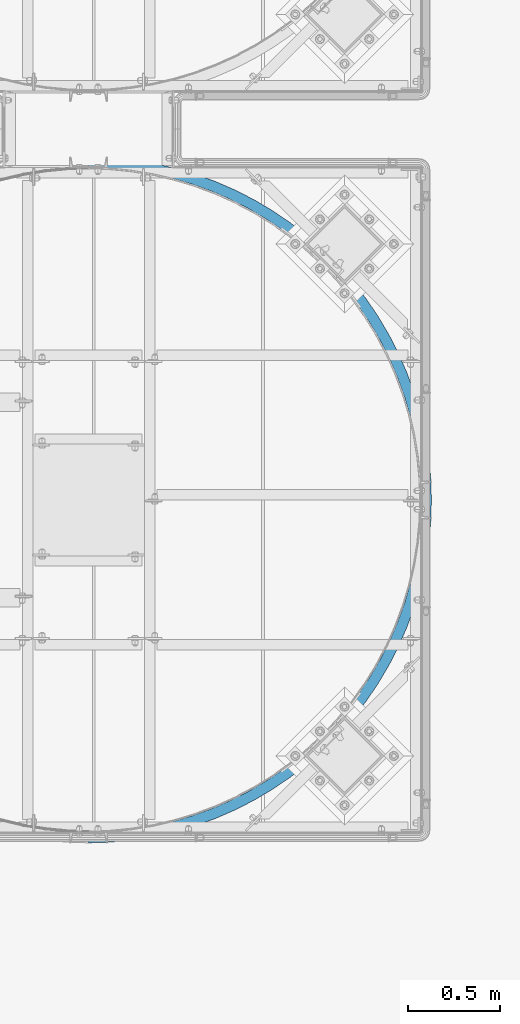
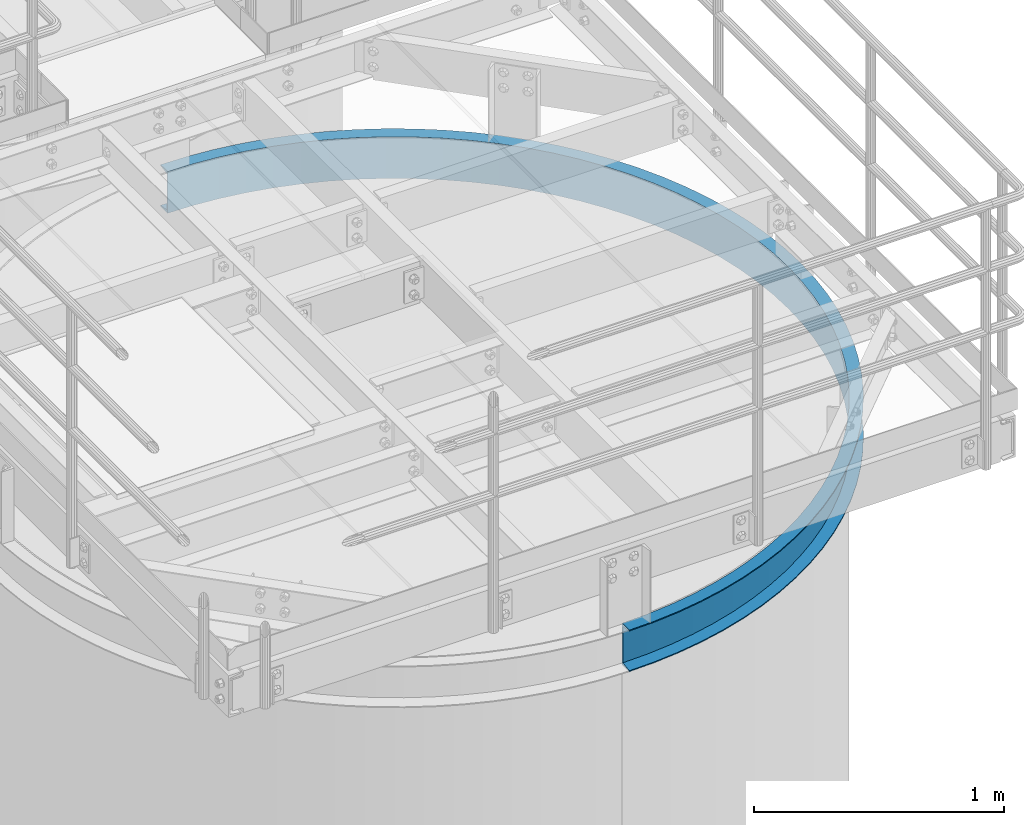
# One storey, part 923 of 1876: 1 beam, 1 element without a shape of its own.
"""IFC2X3 building model written with IfcOpenShell, lengths in millimetres."""

from ifc_helpers import new_model, si_unit, frame, origin_with_axes, place, context, subcontext, project, spatial, faceted_brep, material, type_object, element, aggregate, save


model = new_model("IFC2X3")

# Units and contexts
model_context = context("Model", 3, precision=1e-05, world=origin_with_axes())
body_context = subcontext(model_context, "Body", "Model", "MODEL_VIEW")
ifc_project = project(units=[si_unit("LENGTHUNIT", "METRE", prefix="MILLI"), si_unit("AREAUNIT", "SQUARE_METRE"), si_unit("VOLUMEUNIT", "CUBIC_METRE"), si_unit("MASSUNIT", "GRAM", prefix="KILO"), si_unit("TIMEUNIT", "SECOND"), si_unit("PLANEANGLEUNIT", "RADIAN"), si_unit("SOLIDANGLEUNIT", "STERADIAN"), si_unit("THERMODYNAMICTEMPERATUREUNIT", "DEGREE_CELSIUS"), si_unit("LUMINOUSINTENSITYUNIT", "LUMEN")], contexts=[model_context])

# Site, building, storey
site_placement = place(None, origin_with_axes())
site = spatial("IfcSite", under=ifc_project, at=site_placement, CompositionType="ELEMENT")
building_placement = place(site_placement, origin_with_axes())
building = spatial("IfcBuilding", under=site, at=building_placement, Name="Undefined", CompositionType="ELEMENT")
storey_placement = place(building_placement, origin_with_axes())
storey = spatial("IfcBuildingStorey", under=building, at=storey_placement, Name="Undefined", CompositionType="ELEMENT", Elevation=0.0)

# Assembly, beam
assembly_placement = place(storey_placement, origin_with_axes())
assembly = element("IfcElementAssembly", 1, at=assembly_placement, inside=storey, Name="CHANNEL", AssemblyPlace="NOTDEFINED", PredefinedType="RIGID_FRAME")
ifc_material = material(Name="STEEL/A36")
beam_type = type_object("IfcBeamType", Name="C8X11.5", PredefinedType="NOTDEFINED")
beam_placement = place(assembly_placement, frame((5201.80416918465, -15425.2699805693, 7518.4), z_axis=(0.0, 0.0, 1.0), x_axis=(0.707106781186548, 0.707106781186547, 0.0)))
beam = element("IfcBeam", 2, at=beam_placement, type_object=beam_type, material=ifc_material, Name="CHANNEL", ObjectType="C8X11.5", context=body_context, shape_type="Brep", body=[
    faceted_brep([(-40.4111525448152, -11.8361525448254, -101.6), (-40.4111525448152, -11.8361525448254, -96.8355949999996), (-4.49012806054634, 24.0848719394708, -88.3723149999996), (-4.49012806054634, 24.0848719394708, 88.3723149999996), (-40.4111525448152, -11.8361525448254, 96.8355949999996), (-40.4111525448152, -11.8361525448254, 101.6), (0.0, 28.5749999999998, 101.6), (0.0, 28.5749999999998, -101.6), (83.1681455805992, -49.5250871930584, 101.6), (83.168145580601, -49.5250871930593, -101.6), (45.3741724773627, -92.3939348224612, -101.6), (45.3741724773627, -92.3939348224612, -96.8355949999996), (78.9688152357958, -54.2882924852147, -88.3723149999996), (78.9688152357958, -54.2882924852147, 88.3723149999996), (45.3741724773627, -92.3939348224612, 96.8355949999996), (45.3741724773627, -92.3939348224612, 101.6), (136.048484757743, -167.406249592315, 96.8355949999996), (136.048484757743, -167.406249592315, 101.6), (167.184163083306, -127.266374963614, 88.3723149999996), (167.184163083306, -127.266374963614, -88.3723149999996), (136.048484757743, -167.406249592315, -96.8355949999996), (136.048484757743, -167.406249592315, -101.6), (171.076122874001, -122.248890635026, 101.6), (171.076122874001, -122.248890635026, -101.6), (231.253934210907, -236.577057517859, 96.8355949999996), (231.253934210907, -236.577057517859, 101.6), (259.807769805786, -194.561364344698, 88.3723149999996), (259.807769805786, -194.561364344698, -88.3723149999996), (231.253934210907, -236.577057517859, -96.8355949999996), (231.253934210907, -236.577057517859, -101.6), (263.376999255146, -189.309402698053, 101.6), (263.376999255146, -189.309402698053, -101.6), (330.614788423094, -299.633373021349, 96.8355949999996), (330.614788423094, -299.633373021349, 101.6), (356.474092343207, -255.907678049534, 88.3723149999996), (356.474092343207, -255.907678049534, -88.3723149999996), (330.614788423094, -299.633373021349, -96.8355949999996), (330.614788423094, -299.633373021349, -101.6), (359.706505333223, -250.441966178058, 101.6), (359.706505333223, -250.441966178058, -101.6), (433.738915496391, -356.326341633181, 96.8355949999996), (433.738915496391, -356.326341633181, 101.6), (456.801632883155, -311.063210204398, 88.3723149999996), (456.801632883155, -311.063210204398, -88.3723149999996), (433.738915496391, -356.326341633181, -96.8355949999996), (433.738915496391, -356.326341633181, -101.6), (459.684472556501, -305.4053187758, 101.6), (459.684472556501, -305.4053187758, -101.6), (540.219331614169, -406.432222106796, 96.8355949999996), (540.219331614169, -406.432222106796, 101.6), (560.39444445841, -359.810287122038, 88.3723149999996), (560.39444445841, -359.810287122038, -88.3723149999996), (540.219331614169, -406.432222106796, -96.8355949999996), (540.219331614169, -406.432222106796, -101.6), (562.91633356394, -353.982545248944, 101.6), (562.91633356394, -353.982545248944, -101.6), (649.635807220287, -449.753269423169, 96.8355949999996), (649.635807220287, -449.753269423169, 101.6), (666.843693568744, -401.956526360284, 88.3723149999996), (666.843693568744, -401.956526360284, -88.3723149999996), (649.635807220287, -449.753269423169, -96.8355949999996), (649.635807220287, -449.753269423169, -101.6), (668.9946793623, -395.981933477424, 101.6), (668.9946793623, -395.981933477424, -101.6), (761.556525473163, -486.118515200043, 96.8355949999996), (761.556525473163, -486.118515200043, 101.6), (775.729273659952, -437.335595967645, 88.3723149999996), (775.729273659952, -437.335595967645, -88.3723149999996), (761.556525473163, -486.118515200043, -96.8355949999996), (761.556525473163, -486.118515200043, -101.6), (777.500867183298, -431.237731063595, 101.6), (777.500867183298, -431.237731063595, -101.6), (875.539786429559, -515.384442426039, 96.8355949999996), (875.539786429559, -515.384442426039, 101.6), (886.621463092501, -465.807870919541, 88.3723149999996), (886.621463092501, -465.807870919541, -88.3723149999996), (875.539786429559, -515.384442426039, -96.8355949999996), (875.539786429559, -515.384442426039, -101.6), (888.006672675367, -459.610799481228, 101.6), (888.006672675367, -459.610799481228, -101.6), (991.135750232484, -537.435551856724, 96.8355949999996), (991.135750232484, -537.435551856724, 101.6), (999.082621056526, -487.260984154484, 88.3723149999996), (999.082621056526, -487.260984154484, -88.3723149999996), (991.135750232484, -537.435551856724, -96.8355949999996), (991.135750232484, -537.435551856724, -101.6), (1000.07597990953, -480.989163191702, 101.6), (1000.07597990953, -480.989163191702, -101.6), (1107.88821242358, -552.184817837371, 96.8355949999996), (1107.88821242358, -552.184817837371, 101.6), (1112.66891474016, -501.610270035526, 88.3723149999996), (1112.66891474016, -501.610270035526, -88.3723149999996), (1107.88821242358, -552.184817837371, -96.8355949999996), (1107.88821242358, -552.184817837371, -101.6), (1113.26650252974, -495.288451560295, 101.6), (1113.26650252974, -495.288451560295, -101.6), (1225.33640437371, -559.574031753455, 96.8355949999996), (1225.33640437371, -559.574031753455, 101.6), (1226.93207093488, -508.799098486866, 88.3723149999996), (1226.93207093488, -508.799098486866, -88.3723149999996), (1225.33640437371, -559.574031753455, -96.8355949999996), (1225.33640437371, -559.574031753455, -101.6), (1227.13152925503, -502.452231828542, 101.6), (1227.13152925503, -502.452231828542, -101.6), (1343.01681172622, -559.574031753454, 96.8355949999996), (1343.01681172622, -559.574031753454, 101.6), (1341.42114516505, -508.799098486867, 88.3723149999996), (1341.42114516505, -508.799098486867, -88.3723149999996), (1343.01681172622, -559.574031753454, -96.8355949999996), (1343.01681172622, -559.574031753454, -101.6), (1341.2216868449, -502.452231828544, 101.6), (1341.2216868449, -502.452231828544, -101.6), (1460.46500367634, -552.184817837373, 96.8355949999996), (1460.46500367634, -552.184817837373, 101.6), (1455.68430135976, -501.610270035527, 88.3723149999996), (1455.68430135976, -501.610270035527, -88.3723149999996), (1460.46500367634, -552.184817837373, -96.8355949999996), (1460.46500367634, -552.184817837373, -101.6), (1455.08671357019, -495.288451560297, 101.6), (1455.08671357019, -495.288451560297, -101.6), (1577.21746586744, -537.435551856726, 96.8355949999996), (1577.21746586744, -537.435551856726, 101.6), (1569.2705950434, -487.260984154484, 88.3723149999996), (1569.2705950434, -487.260984154484, -88.3723149999996), (1577.21746586744, -537.435551856726, -96.8355949999996), (1577.21746586744, -537.435551856726, -101.6), (1568.27723619039, -480.989163191705, 101.6), (1568.27723619039, -480.989163191705, -101.6), (1692.81342967037, -515.384442426042, 96.8355949999996), (1692.81342967037, -515.384442426042, 101.6), (1681.73175300743, -465.807870919543, 88.3723149999996), (1681.73175300743, -465.807870919543, -88.3723149999996), (1692.81342967037, -515.384442426042, -96.8355949999996), (1692.81342967037, -515.384442426042, -101.6), (1680.34654342456, -459.610799481231, 101.6), (1680.34654342456, -459.610799481231, -101.6), (1806.79669062676, -486.118515200047, 96.8355949999996), (1806.79669062676, -486.118515200047, 101.6), (1792.62394243998, -437.335595967647, 88.3723149999996), (1792.62394243998, -437.335595967647, -88.3723149999996), (1806.79669062676, -486.118515200047, -96.8355949999996), (1806.79669062676, -486.118515200047, -101.6), (1790.85234891663, -431.237731063598, 101.6), (1790.85234891663, -431.237731063598, -101.6), (1918.71740887964, -449.753269423174, 96.8355949999996), (1918.71740887964, -449.753269423174, 101.6), (1901.50952253118, -401.956526360288, 88.3723149999996), (1901.50952253118, -401.956526360288, -88.3723149999996), (1918.71740887964, -449.753269423174, -96.8355949999996), (1918.71740887964, -449.753269423174, -101.6), (1899.35853673763, -395.981933477428, 101.6), (1899.35853673763, -395.981933477428, -101.6), (2028.13388448576, -406.432222106803, 96.8355949999996), (2028.13388448576, -406.432222106803, 101.6), (2007.95877164152, -359.810287122044, 88.3723149999996), (2007.95877164152, -359.810287122044, -88.3723149999996), (2028.13388448576, -406.432222106803, -96.8355949999996), (2028.13388448576, -406.432222106803, -101.6), (2005.43688253599, -353.982545248949, 101.6), (2005.43688253599, -353.982545248949, -101.6), (2134.61430060353, -356.326341633187, 96.8355949999996), (2134.61430060353, -356.326341633187, 101.6), (2111.55158321677, -311.063210204405, 88.3723149999996), (2111.55158321677, -311.063210204405, -88.3723149999996), (2134.61430060353, -356.326341633187, -96.8355949999996), (2134.61430060353, -356.326341633187, -101.6), (2108.66874354343, -305.405318775807, 101.6), (2108.66874354343, -305.405318775807, -101.6), (2237.73842767683, -299.633373021357, 96.8355949999996), (2237.73842767683, -299.633373021357, 101.6), (2211.87912375672, -255.907678049542, 88.3723149999996), (2211.87912375672, -255.907678049542, -88.3723149999996), (2237.73842767683, -299.633373021357, -96.8355949999996), (2237.73842767683, -299.633373021357, -101.6), (2208.64671076671, -250.441966178065, 101.6), (2208.64671076671, -250.441966178065, -101.6), (2337.09928188902, -236.577057517868, 96.8355949999996), (2337.09928188902, -236.577057517868, 101.6), (2308.54544629414, -194.561364344705, 88.3723149999996), (2308.54544629414, -194.561364344705, -88.3723149999996), (2337.09928188902, -236.577057517868, -96.8355949999996), (2337.09928188902, -236.577057517868, -101.6), (2304.97621684478, -189.30940269806, 101.6), (2304.97621684478, -189.30940269806, -101.6), (2432.30473134219, -167.406249592324, 96.8355949999996), (2432.30473134219, -167.406249592324, 101.6), (2401.16905301662, -127.266374963622, 88.3723149999996), (2401.16905301662, -127.266374963622, -88.3723149999996), (2432.30473134219, -167.406249592324, -96.8355949999996), (2432.30473134219, -167.406249592324, -101.6), (2397.27709322593, -122.248890635034, 101.6), (2397.27709322593, -122.248890635034, -101.6), (2522.97904362256, -92.3939348224685, 96.8355949999996), (2522.97904362256, -92.3939348224685, 101.6), (2489.38440086413, -54.2882924852247, 88.3723149999996), (2489.38440086413, -54.2882924852247, -88.3723149999996), (2522.97904362256, -92.3939348224685, -96.8355949999996), (2522.97904362256, -92.3939348224685, -101.6), (2485.18507051933, -49.5250871930684, 101.6), (2485.18507051933, -49.5250871930684, -101.6), (2608.76436864474, -11.8361525448345, 96.8355949999996), (2608.76436864474, -11.8361525448345, 101.6), (2572.84334416047, 24.0848719394626, 88.3723149999996), (2572.84334416047, 24.0848719394626, -88.3723149999996), (2608.76436864474, -11.8361525448345, -96.8355949999996), (2608.76436864474, -11.8361525448345, -101.6), (2568.35321609994, 28.5749999999989, 101.6), (2568.35321609993, 28.5749999999989, -101.6), (2764.3344656923, 164.623484757718, 101.6), (2833.50527361787, 259.828934210873, 101.6), (2896.56158912139, 359.189788423056, 101.6), (2953.25455773324, 462.313915496351, 101.6), (3003.36043820688, 568.794331614128, 101.6), (3046.68148552328, 678.210807220248, 101.6), (3083.04673130017, 790.131525473126, 101.6), (3112.31265852618, 904.114786429529, 101.6), (3134.36376795688, 1019.71075023246, 101.6), (3149.11303393754, 1136.46321242357, 101.6), (3156.50224785364, 1253.91140437371, 101.6), (3156.50224785364, 1371.59181172622, 101.6), (3149.11303393757, 1489.04000367636, 101.6), (3134.36376795692, 1605.79246586747, 101.6), (3112.31265852624, 1721.38842967041, 101.6), (3083.04673130024, 1835.37169062681, 101.6), (3046.68148552336, 1947.2924088797, 101.6), (3003.36043820698, 2056.70888448582, 101.6), (2953.25455773336, 2163.18930060361, 101.6), (2896.56158912152, 2266.31342767691, 101.6), (2833.50527361802, 2365.67428188911, 101.6), (2764.33446569245, 2460.87973134227, 101.6), (2689.32215092258, 2551.55404362265, 101.6), (2608.76436864493, 2637.33936864483, 101.6), (2568.3532161001, 2596.92821610002, 101.6), (2646.45330329319, 2513.76007051941, 101.6), (2719.17710673517, 2425.85209322601, 101.6), (2786.23761879821, 2333.55121684486, 101.6), (2847.37018227823, 2237.22171076678, 101.6), (2902.33353487598, 2137.2437435435, 101.6), (2950.91076134913, 2034.01188253605, 101.6), (2992.91014957762, 1927.93353673768, 101.6), (3028.16594716379, 1819.42734891668, 101.6), (3056.53901558143, 1708.9215434246, 101.6), (3077.9173792919, 1596.85223619042, 101.6), (3092.21666766049, 1483.66171357021, 101.6), (3099.38044792873, 1369.79668684491, 101.6), (3099.38044792872, 1255.70652925503, 101.6), (3092.21666766047, 1141.84150252973, 101.6), (3077.91737929186, 1028.65097990952, 101.6), (3056.53901558137, 916.581672675346, 101.6), (3028.16594716372, 806.075867183273, 101.6), (2992.91014957753, 697.569679362271, 101.6), (2950.91076134903, 591.49133356391, 101.6), (2902.33353487587, 488.25947255647, 101.6), (2847.3701822781, 388.281505333194, 101.6), (2786.23761879807, 291.951999255124, 101.6), (2719.17710673502, 199.651122873987, 101.6), (2646.45330329302, 111.743145580598, 101.6), (2689.32215092242, 73.9491724773488, 101.6), (2646.45330329302, 111.743145580598, -101.6), (2719.17710673502, 199.651122873987, -101.6), (2786.23761879807, 291.951999255124, -101.6), (2847.3701822781, 388.281505333194, -101.6), (2902.33353487587, 488.25947255647, -101.6), (2950.91076134903, 591.49133356391, -101.6), (2992.91014957753, 697.569679362271, -101.6), (3028.16594716372, 806.075867183273, -101.6), (3056.53901558137, 916.581672675346, -101.6), (3077.91737929186, 1028.65097990952, -101.6), (3092.21666766047, 1141.84150252973, -101.6), (3099.38044792872, 1255.70652925503, -101.6), (3099.38044792873, 1369.79668684491, -101.6), (3092.21666766049, 1483.66171357021, -101.6), (3077.9173792919, 1596.85223619042, -101.6), (3056.53901558143, 1708.9215434246, -101.6), (3028.16594716379, 1819.42734891668, -101.6), (2992.91014957762, 1927.93353673768, -101.6), (2950.91076134913, 2034.01188253605, -101.6), (2902.33353487598, 2137.2437435435, -101.6), (2847.37018227823, 2237.22171076678, -101.6), (2786.23761879821, 2333.55121684486, -101.6), (2719.17710673517, 2425.85209322601, -101.6), (2646.45330329319, 2513.76007051941, -101.6), (2568.3532161001, 2596.92821610002, -101.6), (2608.76436864493, 2637.33936864483, -101.6), (2689.32215092258, 2551.55404362265, -101.6), (2764.33446569245, 2460.87973134227, -101.6), (2833.50527361802, 2365.67428188911, -101.6), (2896.56158912152, 2266.31342767691, -101.6), (2953.25455773336, 2163.18930060361, -101.6), (3003.36043820698, 2056.70888448582, -101.6), (3046.68148552336, 1947.2924088797, -101.6), (3083.04673130024, 1835.37169062681, -101.6), (3112.31265852624, 1721.38842967041, -101.6), (3134.36376795692, 1605.79246586747, -101.6), (3149.11303393757, 1489.04000367636, -101.6), (3156.50224785364, 1371.59181172622, -101.6), (3156.50224785364, 1253.91140437371, -101.6), (3149.11303393754, 1136.46321242357, -101.6), (3134.36376795688, 1019.71075023246, -101.6), (3112.31265852618, 904.114786429529, -101.6), (3083.04673130017, 790.131525473126, -101.6), (3046.68148552328, 678.210807220248, -101.6), (3003.36043820688, 568.794331614128, -101.6), (2953.25455773324, 462.313915496351, -101.6), (2896.56158912139, 359.189788423056, -101.6), (2833.50527361787, 259.828934210873, -101.6), (2764.3344656923, 164.623484757718, -101.6), (2689.32215092242, 73.9491724773488, -101.6), (2689.32215092242, 73.9491724773488, -96.8355949999996), (2651.21650858518, 107.543815235792, -88.3723149999996), (2651.21650858518, 107.543815235792, 88.3723149999996), (2689.32215092242, 73.9491724773488, 96.8355949999996), (2764.3344656923, 164.623484757718, 96.8355949999996), (2724.19459106361, 195.75916308329, 88.3723149999996), (2724.19459106361, 195.75916308329, -88.3723149999996), (2764.3344656923, 164.623484757718, -96.8355949999996), (2833.50527361787, 259.828934210873, 96.8355949999996), (2791.48958044472, 288.382769805763, 88.3723149999996), (2791.48958044472, 288.382769805763, -88.3723149999996), (2833.50527361787, 259.828934210873, -96.8355949999996), (2896.56158912139, 359.189788423056, 96.8355949999996), (2852.83589414958, 385.049092343178, 88.3723149999996), (2852.83589414958, 385.049092343178, -88.3723149999996), (2896.56158912139, 359.189788423056, -96.8355949999996), (2953.25455773324, 462.313915496351, 96.8355949999996), (2907.99142630447, 485.376632883123, 88.3723149999996), (2907.99142630447, 485.376632883123, -88.3723149999996), (2953.25455773324, 462.313915496351, -96.8355949999996), (3003.36043820688, 568.794331614128, 96.8355949999996), (2956.73850322213, 588.969444458379, 88.3723149999996), (2956.73850322213, 588.969444458379, -88.3723149999996), (3003.36043820688, 568.794331614128, -96.8355949999996), (3046.68148552328, 678.210807220248, 96.8355949999996), (2998.88474246039, 695.418693568713, 88.3723149999996), (2998.88474246039, 695.418693568713, -88.3723149999996), (3046.68148552328, 678.210807220248, -96.8355949999996), (3083.04673130017, 790.131525473126, 96.8355949999996), (3034.26381206777, 804.304273659922, 88.3723149999996), (3034.26381206777, 804.304273659922, -88.3723149999996), (3083.04673130017, 790.131525473126, -96.8355949999996), (3112.31265852618, 904.114786429529, 96.8355949999996), (3062.73608701968, 915.196463092477, 88.3723149999996), (3062.73608701968, 915.196463092477, -88.3723149999996), (3112.31265852618, 904.114786429529, -96.8355949999996), (3134.36376795688, 1019.71075023246, 96.8355949999996), (3084.18920025464, 1027.65762105651, 88.3723149999996), (3084.18920025464, 1027.65762105651, -88.3723149999996), (3134.36376795688, 1019.71075023246, -96.8355949999996), (3149.11303393754, 1136.46321242357, 96.8355949999996), (3098.5384861357, 1141.24391474015, 88.3723149999996), (3098.5384861357, 1141.24391474015, -88.3723149999996), (3149.11303393754, 1136.46321242357, -96.8355949999996), (3156.50224785364, 1253.91140437371, 96.8355949999996), (3105.72731458705, 1255.50707093488, 88.3723149999996), (3105.72731458705, 1255.50707093488, -88.3723149999996), (3156.50224785364, 1253.91140437371, -96.8355949999996), (3156.50224785364, 1371.59181172622, 96.8355949999996), (3105.72731458705, 1369.99614516506, 88.3723149999996), (3105.72731458705, 1369.99614516506, -88.3723149999996), (3156.50224785364, 1371.59181172622, -96.8355949999996), (3149.11303393757, 1489.04000367636, 96.8355949999996), (3098.53848613572, 1484.25930135978, 88.3723149999996), (3098.53848613572, 1484.25930135978, -88.3723149999996), (3149.11303393757, 1489.04000367636, -96.8355949999996), (3134.36376795692, 1605.79246586747, 96.8355949999996), (3084.18920025468, 1597.84559504343, 88.3723149999996), (3084.18920025468, 1597.84559504343, -88.3723149999996), (3134.36376795692, 1605.79246586747, -96.8355949999996), (3112.31265852624, 1721.38842967041, 96.8355949999996), (3062.73608701974, 1710.30675300747, 88.3723149999996), (3062.73608701974, 1710.30675300747, -88.3723149999996), (3112.31265852624, 1721.38842967041, -96.8355949999996), (3083.04673130024, 1835.37169062681, 96.8355949999996), (3034.26381206784, 1821.19894244003, 88.3723149999996), (3034.26381206784, 1821.19894244003, -88.3723149999996), (3083.04673130024, 1835.37169062681, -96.8355949999996), (3046.68148552336, 1947.2924088797, 96.8355949999996), (2998.88474246048, 1930.08452253124, 88.3723149999996), (2998.88474246048, 1930.08452253124, -88.3723149999996), (3046.68148552336, 1947.2924088797, -96.8355949999996), (3003.36043820698, 2056.70888448582, 96.8355949999996), (2956.73850322223, 2036.53377164158, 88.3723149999996), (2956.73850322223, 2036.53377164158, -88.3723149999996), (3003.36043820698, 2056.70888448582, -96.8355949999996), (2953.25455773336, 2163.18930060361, 96.8355949999996), (2907.99142630458, 2140.12658321685, 88.3723149999996), (2907.99142630458, 2140.12658321685, -88.3723149999996), (2953.25455773336, 2163.18930060361, -96.8355949999996), (2896.56158912152, 2266.31342767691, 96.8355949999996), (2852.8358941497, 2240.4541237568, 88.3723149999996), (2852.8358941497, 2240.4541237568, -88.3723149999996), (2896.56158912152, 2266.31342767691, -96.8355949999996), (2833.50527361802, 2365.67428188911, 96.8355949999996), (2791.48958044486, 2337.12044629422, 88.3723149999996), (2791.48958044486, 2337.12044629422, -88.3723149999996), (2833.50527361802, 2365.67428188911, -96.8355949999996), (2764.33446569245, 2460.87973134227, 96.8355949999996), (2724.19459106376, 2429.74405301671, 88.3723149999996), (2724.19459106376, 2429.74405301671, -88.3723149999996), (2764.33446569245, 2460.87973134227, -96.8355949999996), (2689.32215092258, 2551.55404362265, 96.8355949999996), (2651.21650858534, 2517.95940086422, 88.3723149999996), (2651.21650858534, 2517.95940086422, -88.3723149999996), (2689.32215092258, 2551.55404362265, -96.8355949999996), (2608.76436864493, 2637.33936864483, 96.8355949999996), (2572.84334416064, 2601.41834416056, 88.3723149999996), (2572.84334416064, 2601.41834416056, -88.3723149999996), (2608.76436864493, 2637.33936864483, -96.8355949999996)], [[[0, 1, 2, 3, 4, 5, 6, 7]], [[7, 6, 8, 9]], [[1, 0, 10, 11]], [[2, 1, 11, 12]], [[3, 2, 12, 13]], [[4, 3, 13, 14]], [[5, 4, 14, 15]], [[14, 16, 17, 15]], [[13, 18, 16, 14]], [[12, 19, 18, 13]], [[11, 20, 19, 12]], [[10, 21, 20, 11]], [[8, 22, 23, 9]], [[16, 24, 25, 17]], [[18, 26, 24, 16]], [[19, 27, 26, 18]], [[20, 28, 27, 19]], [[21, 29, 28, 20]], [[22, 30, 31, 23]], [[24, 32, 33, 25]], [[26, 34, 32, 24]], [[27, 35, 34, 26]], [[28, 36, 35, 27]], [[29, 37, 36, 28]], [[30, 38, 39, 31]], [[32, 40, 41, 33]], [[34, 42, 40, 32]], [[35, 43, 42, 34]], [[36, 44, 43, 35]], [[37, 45, 44, 36]], [[38, 46, 47, 39]], [[40, 48, 49, 41]], [[42, 50, 48, 40]], [[43, 51, 50, 42]], [[44, 52, 51, 43]], [[45, 53, 52, 44]], [[46, 54, 55, 47]], [[48, 56, 57, 49]], [[50, 58, 56, 48]], [[51, 59, 58, 50]], [[52, 60, 59, 51]], [[53, 61, 60, 52]], [[54, 62, 63, 55]], [[56, 64, 65, 57]], [[58, 66, 64, 56]], [[59, 67, 66, 58]], [[60, 68, 67, 59]], [[61, 69, 68, 60]], [[62, 70, 71, 63]], [[64, 72, 73, 65]], [[66, 74, 72, 64]], [[67, 75, 74, 66]], [[68, 76, 75, 67]], [[69, 77, 76, 68]], [[70, 78, 79, 71]], [[72, 80, 81, 73]], [[74, 82, 80, 72]], [[75, 83, 82, 74]], [[76, 84, 83, 75]], [[77, 85, 84, 76]], [[78, 86, 87, 79]], [[80, 88, 89, 81]], [[82, 90, 88, 80]], [[83, 91, 90, 82]], [[84, 92, 91, 83]], [[85, 93, 92, 84]], [[86, 94, 95, 87]], [[88, 96, 97, 89]], [[90, 98, 96, 88]], [[91, 99, 98, 90]], [[92, 100, 99, 91]], [[93, 101, 100, 92]], [[94, 102, 103, 95]], [[96, 104, 105, 97]], [[98, 106, 104, 96]], [[99, 107, 106, 98]], [[100, 108, 107, 99]], [[101, 109, 108, 100]], [[102, 110, 111, 103]], [[104, 112, 113, 105]], [[106, 114, 112, 104]], [[107, 115, 114, 106]], [[108, 116, 115, 107]], [[109, 117, 116, 108]], [[110, 118, 119, 111]], [[112, 120, 121, 113]], [[114, 122, 120, 112]], [[115, 123, 122, 114]], [[116, 124, 123, 115]], [[117, 125, 124, 116]], [[118, 126, 127, 119]], [[120, 128, 129, 121]], [[122, 130, 128, 120]], [[123, 131, 130, 122]], [[124, 132, 131, 123]], [[125, 133, 132, 124]], [[126, 134, 135, 127]], [[128, 136, 137, 129]], [[130, 138, 136, 128]], [[131, 139, 138, 130]], [[132, 140, 139, 131]], [[133, 141, 140, 132]], [[134, 142, 143, 135]], [[136, 144, 145, 137]], [[138, 146, 144, 136]], [[139, 147, 146, 138]], [[140, 148, 147, 139]], [[141, 149, 148, 140]], [[142, 150, 151, 143]], [[144, 152, 153, 145]], [[146, 154, 152, 144]], [[147, 155, 154, 146]], [[148, 156, 155, 147]], [[149, 157, 156, 148]], [[150, 158, 159, 151]], [[152, 160, 161, 153]], [[154, 162, 160, 152]], [[155, 163, 162, 154]], [[156, 164, 163, 155]], [[157, 165, 164, 156]], [[158, 166, 167, 159]], [[160, 168, 169, 161]], [[162, 170, 168, 160]], [[163, 171, 170, 162]], [[164, 172, 171, 163]], [[165, 173, 172, 164]], [[166, 174, 175, 167]], [[168, 176, 177, 169]], [[170, 178, 176, 168]], [[171, 179, 178, 170]], [[172, 180, 179, 171]], [[173, 181, 180, 172]], [[174, 182, 183, 175]], [[176, 184, 185, 177]], [[178, 186, 184, 176]], [[179, 187, 186, 178]], [[180, 188, 187, 179]], [[181, 189, 188, 180]], [[182, 190, 191, 183]], [[184, 192, 193, 185]], [[186, 194, 192, 184]], [[187, 195, 194, 186]], [[188, 196, 195, 187]], [[189, 197, 196, 188]], [[190, 198, 199, 191]], [[192, 200, 201, 193]], [[194, 202, 200, 192]], [[195, 203, 202, 194]], [[196, 204, 203, 195]], [[197, 205, 204, 196]], [[198, 206, 207, 199]], [[208, 209, 210, 211, 212, 213, 214, 215, 216, 217, 218, 219, 220, 221, 222, 223, 224, 225, 226, 227, 228, 229, 230, 231, 232, 233, 234, 235, 236, 237, 238, 239, 240, 241, 242, 243, 244, 245, 246, 247, 248, 249, 250, 251, 252, 253, 254, 255, 256, 206, 198, 190, 182, 174, 166, 158, 150, 142, 134, 126, 118, 110, 102, 94, 86, 78, 70, 62, 54, 46, 38, 30, 22, 8, 6, 5, 15, 17, 25, 33, 41, 49, 57, 65, 73, 81, 89, 97, 105, 113, 121, 129, 137, 145, 153, 161, 169, 177, 185, 193, 201, 257]], [[207, 206, 256, 258]], [[259, 260, 261, 262, 263, 264, 265, 266, 267, 268, 269, 270, 271, 272, 273, 274, 275, 276, 277, 278, 279, 280, 281, 282, 283, 284, 285, 286, 287, 288, 289, 290, 291, 292, 293, 294, 295, 296, 297, 298, 299, 300, 301, 302, 303, 304, 305, 306, 307, 205, 197, 189, 181, 173, 165, 157, 149, 141, 133, 125, 117, 109, 101, 93, 85, 77, 69, 61, 53, 45, 37, 29, 21, 10, 0, 7, 9, 23, 31, 39, 47, 55, 63, 71, 79, 87, 95, 103, 111, 119, 127, 135, 143, 151, 159, 167, 175, 183, 191, 199, 207, 258]], [[204, 205, 307, 308]], [[203, 204, 308, 309]], [[202, 203, 309, 310]], [[200, 202, 310, 311]], [[201, 200, 311, 257]], [[311, 312, 208, 257]], [[310, 313, 312, 311]], [[309, 314, 313, 310]], [[308, 315, 314, 309]], [[307, 306, 315, 308]], [[256, 255, 259, 258]], [[312, 316, 209, 208]], [[313, 317, 316, 312]], [[314, 318, 317, 313]], [[315, 319, 318, 314]], [[306, 305, 319, 315]], [[255, 254, 260, 259]], [[316, 320, 210, 209]], [[317, 321, 320, 316]], [[318, 322, 321, 317]], [[319, 323, 322, 318]], [[305, 304, 323, 319]], [[254, 253, 261, 260]], [[320, 324, 211, 210]], [[321, 325, 324, 320]], [[322, 326, 325, 321]], [[323, 327, 326, 322]], [[304, 303, 327, 323]], [[253, 252, 262, 261]], [[324, 328, 212, 211]], [[325, 329, 328, 324]], [[326, 330, 329, 325]], [[327, 331, 330, 326]], [[303, 302, 331, 327]], [[252, 251, 263, 262]], [[328, 332, 213, 212]], [[329, 333, 332, 328]], [[330, 334, 333, 329]], [[331, 335, 334, 330]], [[302, 301, 335, 331]], [[251, 250, 264, 263]], [[332, 336, 214, 213]], [[333, 337, 336, 332]], [[334, 338, 337, 333]], [[335, 339, 338, 334]], [[301, 300, 339, 335]], [[250, 249, 265, 264]], [[336, 340, 215, 214]], [[337, 341, 340, 336]], [[338, 342, 341, 337]], [[339, 343, 342, 338]], [[300, 299, 343, 339]], [[249, 248, 266, 265]], [[340, 344, 216, 215]], [[341, 345, 344, 340]], [[342, 346, 345, 341]], [[343, 347, 346, 342]], [[299, 298, 347, 343]], [[248, 247, 267, 266]], [[344, 348, 217, 216]], [[345, 349, 348, 344]], [[346, 350, 349, 345]], [[347, 351, 350, 346]], [[298, 297, 351, 347]], [[247, 246, 268, 267]], [[348, 352, 218, 217]], [[349, 353, 352, 348]], [[350, 354, 353, 349]], [[351, 355, 354, 350]], [[297, 296, 355, 351]], [[246, 245, 269, 268]], [[352, 356, 219, 218]], [[353, 357, 356, 352]], [[354, 358, 357, 353]], [[355, 359, 358, 354]], [[296, 295, 359, 355]], [[245, 244, 270, 269]], [[356, 360, 220, 219]], [[357, 361, 360, 356]], [[358, 362, 361, 357]], [[359, 363, 362, 358]], [[295, 294, 363, 359]], [[244, 243, 271, 270]], [[360, 364, 221, 220]], [[361, 365, 364, 360]], [[362, 366, 365, 361]], [[363, 367, 366, 362]], [[294, 293, 367, 363]], [[243, 242, 272, 271]], [[364, 368, 222, 221]], [[365, 369, 368, 364]], [[366, 370, 369, 365]], [[367, 371, 370, 366]], [[293, 292, 371, 367]], [[242, 241, 273, 272]], [[368, 372, 223, 222]], [[369, 373, 372, 368]], [[370, 374, 373, 369]], [[371, 375, 374, 370]], [[292, 291, 375, 371]], [[241, 240, 274, 273]], [[372, 376, 224, 223]], [[373, 377, 376, 372]], [[374, 378, 377, 373]], [[375, 379, 378, 374]], [[291, 290, 379, 375]], [[240, 239, 275, 274]], [[376, 380, 225, 224]], [[377, 381, 380, 376]], [[378, 382, 381, 377]], [[379, 383, 382, 378]], [[290, 289, 383, 379]], [[239, 238, 276, 275]], [[380, 384, 226, 225]], [[381, 385, 384, 380]], [[382, 386, 385, 381]], [[383, 387, 386, 382]], [[289, 288, 387, 383]], [[238, 237, 277, 276]], [[384, 388, 227, 226]], [[385, 389, 388, 384]], [[386, 390, 389, 385]], [[387, 391, 390, 386]], [[288, 287, 391, 387]], [[237, 236, 278, 277]], [[388, 392, 228, 227]], [[389, 393, 392, 388]], [[390, 394, 393, 389]], [[391, 395, 394, 390]], [[287, 286, 395, 391]], [[236, 235, 279, 278]], [[392, 396, 229, 228]], [[393, 397, 396, 392]], [[394, 398, 397, 393]], [[395, 399, 398, 394]], [[286, 285, 399, 395]], [[235, 234, 280, 279]], [[396, 400, 230, 229]], [[397, 401, 400, 396]], [[398, 402, 401, 397]], [[399, 403, 402, 398]], [[285, 284, 403, 399]], [[234, 233, 281, 280]], [[231, 404, 405, 406, 407, 283, 282, 232]], [[400, 404, 231, 230]], [[401, 405, 404, 400]], [[402, 406, 405, 401]], [[403, 407, 406, 402]], [[284, 283, 407, 403]], [[233, 232, 282, 281]]]),
])
aggregate(assembly, [beam])

save(model, "model.ifc")
